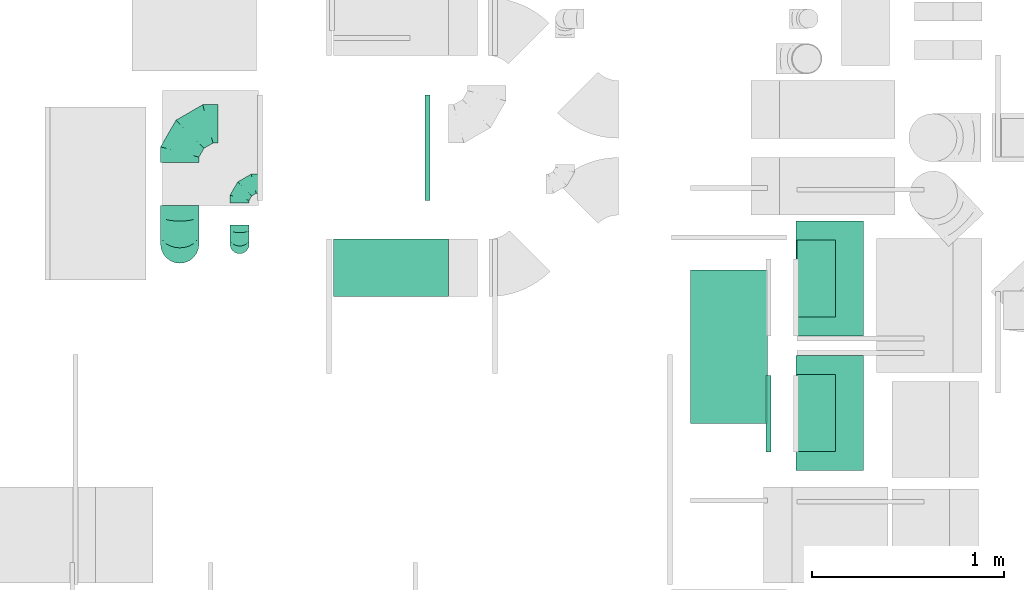
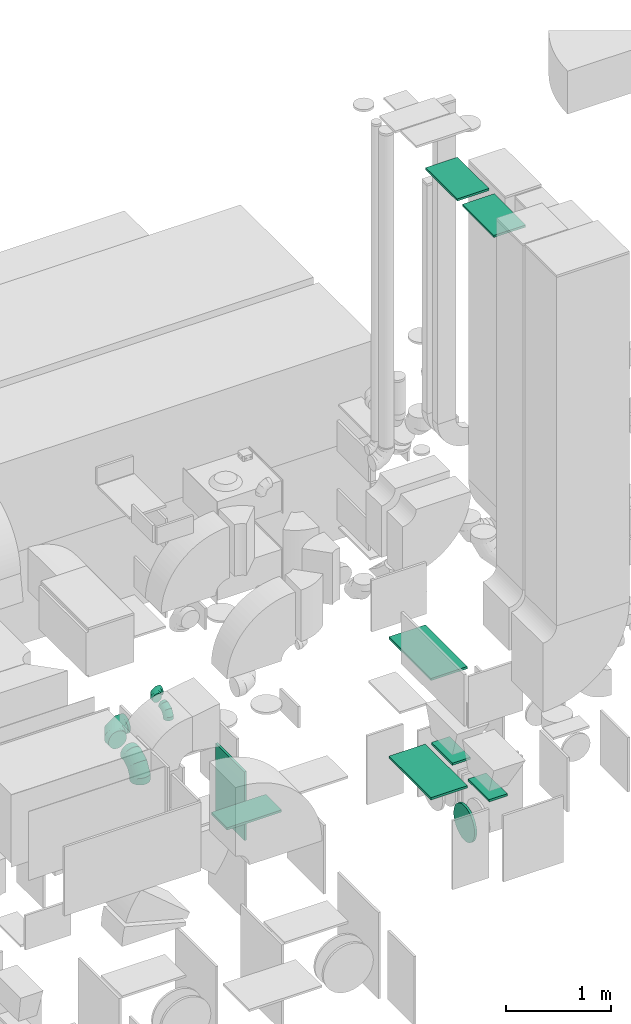
# One storey, part 15 of 59: 13 flow fittings.
"""IFC2X3 building model written with IfcOpenShell, lengths in millimetres."""

from ifc_helpers import new_model, entity, si_unit, converted_unit, derived_unit, direction, frame, origin, origin_2d_with_axis, place, context, subcontext, project, spatial, rectangle, extrude, faceted_brep, source, transform, mapped, material, type_object, type_shapes, element, save


model = new_model("IFC2X3")

# Units and contexts
model_context = context("Model", 3, precision=0.01, world=origin(), true_north=direction((6.12303176911189e-17, 1.0)))
body_context = subcontext(model_context, "Body", "Model", "MODEL_VIEW")
ifc_project = project(units=[si_unit("LENGTHUNIT", "METRE", prefix="MILLI"), si_unit("AREAUNIT", "SQUARE_METRE"), si_unit("VOLUMEUNIT", "CUBIC_METRE"), converted_unit("PLANEANGLEUNIT", "DEGREE", entity("IfcRatioMeasure", 0.0174532925199433), si_unit("PLANEANGLEUNIT", "RADIAN"), dimensions=[0, 0, 0, 0, 0, 0, 0]), si_unit("MASSUNIT", "GRAM", prefix="KILO"), derived_unit("MASSDENSITYUNIT", [(si_unit("MASSUNIT", "GRAM", prefix="KILO"), 1), (si_unit("LENGTHUNIT", "METRE"), -3)]), derived_unit("MOMENTOFINERTIAUNIT", [(si_unit("LENGTHUNIT", "METRE"), 4)]), si_unit("TIMEUNIT", "SECOND"), si_unit("FREQUENCYUNIT", "HERTZ"), si_unit("THERMODYNAMICTEMPERATUREUNIT", "DEGREE_CELSIUS"), derived_unit("THERMALTRANSMITTANCEUNIT", [(si_unit("MASSUNIT", "GRAM", prefix="KILO"), 1), (si_unit("THERMODYNAMICTEMPERATUREUNIT", "KELVIN"), -1), (si_unit("TIMEUNIT", "SECOND"), -3)]), derived_unit("VOLUMETRICFLOWRATEUNIT", [(si_unit("LENGTHUNIT", "METRE"), 3), (si_unit("TIMEUNIT", "SECOND"), -1)]), derived_unit("MASSFLOWRATEUNIT", [(si_unit("MASSUNIT", "GRAM", prefix="KILO"), 1), (si_unit("TIMEUNIT", "SECOND"), -1)]), derived_unit("ROTATIONALFREQUENCYUNIT", [(si_unit("TIMEUNIT", "SECOND"), -1)]), si_unit("ELECTRICCURRENTUNIT", "AMPERE"), si_unit("ELECTRICVOLTAGEUNIT", "VOLT"), si_unit("POWERUNIT", "WATT"), si_unit("FORCEUNIT", "NEWTON", prefix="KILO"), si_unit("ILLUMINANCEUNIT", "LUX"), si_unit("LUMINOUSFLUXUNIT", "LUMEN"), si_unit("LUMINOUSINTENSITYUNIT", "CANDELA"), derived_unit("USERDEFINED", [(si_unit("MASSUNIT", "GRAM", prefix="KILO"), -1), (si_unit("LENGTHUNIT", "METRE"), -2), (si_unit("TIMEUNIT", "SECOND"), 3), (si_unit("LUMINOUSFLUXUNIT", "LUMEN"), 1)]), derived_unit("LINEARVELOCITYUNIT", [(si_unit("LENGTHUNIT", "METRE"), 1), (si_unit("TIMEUNIT", "SECOND"), -1)]), si_unit("PRESSUREUNIT", "PASCAL"), derived_unit("USERDEFINED", [(si_unit("LENGTHUNIT", "METRE"), -2), (si_unit("MASSUNIT", "GRAM", prefix="KILO"), 1), (si_unit("TIMEUNIT", "SECOND"), -2)]), derived_unit("LINEARFORCEUNIT", [(si_unit("MASSUNIT", "GRAM", prefix="KILO"), 1), (si_unit("LENGTHUNIT", "METRE"), 1), (si_unit("TIMEUNIT", "SECOND"), -2), (si_unit("LENGTHUNIT", "METRE"), -1)]), derived_unit("PLANARFORCEUNIT", [(si_unit("MASSUNIT", "GRAM", prefix="KILO"), 1), (si_unit("LENGTHUNIT", "METRE"), 1), (si_unit("TIMEUNIT", "SECOND"), -2), (si_unit("LENGTHUNIT", "METRE"), -2)])], contexts=[model_context])

# Site, building, storey
site_placement = place(None, origin())
site = spatial("IfcSite", under=ifc_project, at=site_placement, CompositionType="ELEMENT")
building_placement = place(site_placement, origin())
building = spatial("IfcBuilding", under=site, at=building_placement, CompositionType="ELEMENT")
storey_placement = place(building_placement, frame((0.0, 0.0, 28200.0)))
storey = spatial("IfcBuildingStorey", under=building, at=storey_placement, CompositionType="ELEMENT", Elevation=28200.0)

# Flow fittings
ifc_material = material()
duct_fitting_type_1 = type_object("IfcDuctFittingType", PredefinedType="NOTDEFINED", material=ifc_material)
shared_shape_1 = source(origin(), body_context, "Body", "SweptSolid", [
    extrude(rectangle(XDim=26.0960000000006, YDim=400.0, at=origin_2d_with_axis()), frame((6.95, 0.0, -100.0)), (0.0, 0.0, 1.0), 200.0),
])
type_shapes(duct_fitting_type_1, [shared_shape_1])
flow_fitting_1_placement = place(storey_placement, frame((48410.88, 10109.01, 970.0), z_axis=(-1.0, 0.0, 0.0), x_axis=(0.0, 0.0, 1.0)))
element("IfcFlowFitting", 1, at=flow_fitting_1_placement, inside=storey, type_object=duct_fitting_type_1, material=ifc_material, context=body_context, shape_type="MappedRepresentation", body=[
    mapped(shared_shape_1, transform((0.0, 0.0, 0.0), scale=1.0)),
])
duct_fitting_type_2 = type_object("IfcDuctFittingType", PredefinedType="NOTDEFINED", material=ifc_material)
shared_shape_2 = source(origin(), body_context, "Body", "SweptSolid", [
    extrude(rectangle(XDim=24.9999999999999, YDim=600.0, at=origin_2d_with_axis()), frame((12.5, 0.0, -175.0)), (0.0, 0.0, 1.0), 350.0),
])
type_shapes(duct_fitting_type_2, [shared_shape_2])
for number, where, z_axis, x_axis in (
    (2, (48480.88, 10109.01, 7587.0), (1.0, 0.0, 0.0), (0.0, 0.0, 1.0)),
    (3, (48480.88, 10809.01, 7587.0), (1.0, 0.0, 0.0), (0.0, 0.0, 1.0)),
):
    element("IfcFlowFitting", number, at=place(storey_placement, frame(where, z_axis=z_axis, x_axis=x_axis)), inside=storey, type_object=duct_fitting_type_2, material=ifc_material, context=body_context, shape_type="MappedRepresentation", body=[
        mapped(shared_shape_2, transform((0.0, 0.0, 0.0), scale=1.0)),
    ])
duct_fitting_type_3 = type_object("IfcDuctFittingType", PredefinedType="NOTDEFINED", material=ifc_material)
shared_shape_3 = source(origin(), body_context, "Body", "SweptSolid", [
    extrude(rectangle(XDim=300.0, YDim=26.0960000000433, at=origin_2d_with_axis()), frame((6.95, 0.0, -300.0), z_axis=(0.0, 0.0, 1.0), x_axis=(0.0, -1.0, 0.0)), (0.0, 0.0, 1.0), 600.0),
])
type_shapes(duct_fitting_type_3, [shared_shape_3])
flow_fitting_2_placement = place(storey_placement, frame((46194.5, 10864.6, 1000.0), z_axis=(1.0, 0.0, 0.0), x_axis=(0.0, 0.0, 1.0)))
element("IfcFlowFitting", 4, at=flow_fitting_2_placement, inside=storey, type_object=duct_fitting_type_3, material=ifc_material, context=body_context, shape_type="MappedRepresentation", body=[
    mapped(shared_shape_3, transform((0.0, 0.0, 0.0), scale=1.0)),
])
duct_fitting_type_4 = type_object("IfcDuctFittingType", PredefinedType="NOTDEFINED", material=ifc_material)
shared_shape_4 = source(origin(), body_context, "Body", "SweptSolid", [
    extrude(rectangle(XDim=24.9999999999999, YDim=550.0, at=origin_2d_with_axis()), frame((12.5, 0.0, -400.0)), (0.0, 0.0, 1.0), 800.0),
])
type_shapes(duct_fitting_type_4, [shared_shape_4])
flow_fitting_3_placement = place(storey_placement, frame((46373.53, 11489.6, 800.0)))
element("IfcFlowFitting", 5, at=flow_fitting_3_placement, inside=storey, type_object=duct_fitting_type_4, material=ifc_material, context=body_context, shape_type="MappedRepresentation", body=[
    mapped(shared_shape_4, transform((0.0, 0.0, 0.0), scale=1.0)),
])
duct_fitting_type_5 = type_object("IfcDuctFittingType", PredefinedType="NOTDEFINED", material=ifc_material)
shared_shape_5 = source(origin(), body_context, "Body", "SweptSolid", [
    extrude(rectangle(XDim=400.0, YDim=26.096, at=origin_2d_with_axis()), frame((6.95, 0.0, -100.0), z_axis=(0.0, 0.0, 1.0), x_axis=(0.0, -1.0, 0.0)), (0.0, 0.0, 1.0), 200.0),
])
type_shapes(duct_fitting_type_5, [shared_shape_5])
flow_fitting_4_placement = place(storey_placement, frame((48410.88, 10809.01, 970.0), z_axis=(-1.0, 0.0, 0.0), x_axis=(0.0, 0.0, 1.0)))
element("IfcFlowFitting", 6, at=flow_fitting_4_placement, inside=storey, type_object=duct_fitting_type_5, material=ifc_material, context=body_context, shape_type="MappedRepresentation", body=[
    mapped(shared_shape_5, transform((0.0, 0.0, 0.0), scale=1.0)),
])
duct_fitting_type_6 = type_object("IfcDuctFittingType", PredefinedType="NOTDEFINED", material=ifc_material)
shared_shape_6 = source(origin(), body_context, "Body", "SweptSolid", [
    extrude(rectangle(XDim=400.0, YDim=26.0960000001169, at=origin_2d_with_axis()), frame((6.95, 0.0, -400.0), z_axis=(0.0, 0.0, 1.0), x_axis=(0.0, -1.0, 0.0)), (0.0, 0.0, 1.0), 800.0),
])
type_shapes(duct_fitting_type_6, [shared_shape_6])
for number, where, z_axis, x_axis in (
    (7, (47955.03, 10453.67, 1100.0), (0.0, -1.0, 0.0), (0.0, 0.0, 1.0)),
    (8, (47955.03, 10453.67, 2500.0), (0.0, -1.0, 0.0), (0.0, 0.0, -1.0)),
):
    element("IfcFlowFitting", number, at=place(storey_placement, frame(where, z_axis=z_axis, x_axis=x_axis)), inside=storey, type_object=duct_fitting_type_6, material=ifc_material, context=body_context, shape_type="MappedRepresentation", body=[
        mapped(shared_shape_6, transform((0.0, 0.0, 0.0), scale=1.0)),
    ])
duct_fitting_type_7 = type_object("IfcDuctFittingType", PredefinedType="NOTDEFINED", material=ifc_material)
shared_shape_7 = source(origin(), body_context, "Body", "Brep", [
    faceted_brep([(-100.0, 0.0, -50.0), (-100.0, -12.94, -48.3), (-100.0, -25.0, -43.3), (-100.0, -35.36, -35.36), (-100.0, -43.3, -25.0), (-100.0, -48.3, -12.94), (-100.0, -50.0, 0.0), (-100.0, -48.3, 12.94), (-100.0, -43.3, 25.0), (-100.0, -35.36, 35.36), (-100.0, -25.0, 43.3), (-100.0, -12.94, 48.3), (-100.0, 0.0, 50.0), (-100.0, 12.94, 48.3), (-100.0, 25.0, 43.3), (-100.0, 35.36, 35.36), (-100.0, 43.3, 25.0), (-100.0, 48.3, 12.94), (-100.0, 50.0, 0.0), (-100.0, 48.3, -12.94), (-100.0, 43.3, -25.0), (-100.0, 35.36, -35.36), (-100.0, 25.0, -43.3), (-100.0, 12.94, -48.3), (-76.67, 12.94, 48.3), (-79.9, 25.0, 43.3), (-73.21, 0.0, 50.0), (-82.68, 35.36, 35.36), (-86.15, 48.3, 12.94), (-86.6, 50.0, 0.0), (-84.81, 43.3, 25.0), (-84.81, 43.3, -25.0), (-82.68, 35.36, -35.36), (-86.15, 48.3, -12.94), (-76.67, 12.94, -48.3), (-73.21, 0.0, -50.0), (-79.9, 25.0, -43.3), (-69.74, -12.94, -48.3), (-66.51, -25.0, -43.3), (-63.73, -35.36, -35.36), (-61.6, -43.3, -25.0), (-60.26, -48.3, -12.94), (-59.81, -50.0, 0.0), (-60.26, -48.3, 12.94), (-61.6, -43.3, 25.0), (-63.73, -35.36, 35.36), (-66.51, -25.0, 43.3), (-69.74, -12.94, 48.3), (-36.27, 36.27, 48.3), (-45.1, 45.1, 43.3), (-26.79, 26.79, 50.0), (-52.68, 52.68, 35.36), (-58.49, 58.49, 25.0), (-62.15, 62.15, 12.94), (-63.4, 63.4, 0.0), (-62.15, 62.15, -12.94), (-58.49, 58.49, -25.0), (-52.68, 52.68, -35.36), (-36.27, 36.27, -48.3), (-26.79, 26.79, -50.0), (-45.1, 45.1, -43.3), (-17.32, 17.32, -48.3), (-8.49, 8.49, -43.3), (-0.91, 0.91, -35.36), (4.9, -4.9, -25.0), (8.56, -8.56, -12.94), (9.81, -9.81, 0.0), (8.56, -8.56, 12.94), (4.9, -4.9, 25.0), (-0.91, 0.91, 35.36), (-8.49, 8.49, 43.3), (-17.32, 17.32, 48.3), (-12.94, 76.67, 48.3), (-25.0, 79.9, 43.3), (0.0, 73.21, 50.0), (-35.36, 82.68, 35.36), (-43.3, 84.81, 25.0), (-48.3, 86.15, 12.94), (-50.0, 86.6, 0.0), (-48.3, 86.15, -12.94), (-43.3, 84.81, -25.0), (-35.36, 82.68, -35.36), (-12.94, 76.67, -48.3), (0.0, 73.21, -50.0), (-25.0, 79.9, -43.3), (12.94, 69.74, -48.3), (25.0, 66.51, -43.3), (35.36, 63.73, -35.36), (43.3, 61.6, -25.0), (48.3, 60.26, -12.94), (50.0, 59.81, 0.0), (48.3, 60.26, 12.94), (43.3, 61.6, 25.0), (35.36, 63.73, 35.36), (25.0, 66.51, 43.3), (12.94, 69.74, 48.3), (-12.94, 100.0, -48.3), (-25.0, 100.0, -43.3), (-35.36, 100.0, -35.36), (-43.3, 100.0, -25.0), (-48.3, 100.0, -12.94), (-50.0, 100.0, 0.0), (-48.3, 100.0, 12.94), (-43.3, 100.0, 25.0), (-35.36, 100.0, 35.36), (-25.0, 100.0, 43.3), (-12.94, 100.0, 48.3), (0.0, 100.0, 50.0), (12.94, 100.0, 48.3), (25.0, 100.0, 43.3), (35.36, 100.0, 35.36), (43.3, 100.0, 25.0), (48.3, 100.0, 12.94), (50.0, 100.0, 0.0), (48.3, 100.0, -12.94), (43.3, 100.0, -25.0), (35.36, 100.0, -35.36), (25.0, 100.0, -43.3), (12.94, 100.0, -48.3), (0.0, 100.0, -50.0)], [[[0, 1, 2, 3, 4, 5, 6, 7, 8, 9, 10, 11, 12, 13, 14, 15, 16, 17, 18, 19, 20, 21, 22, 23]], [[24, 25, 14, 13]], [[26, 24, 13, 12]], [[14, 25, 27, 15]], [[28, 29, 18, 17]], [[30, 28, 17, 16]], [[15, 27, 30, 16]], [[20, 31, 32, 21]], [[33, 31, 20, 19]], [[18, 29, 33, 19]], [[34, 35, 0, 23]], [[36, 34, 23, 22]], [[32, 36, 22, 21]], [[2, 1, 37, 38]], [[3, 2, 38, 39]], [[0, 35, 37, 1]], [[5, 4, 40, 41]], [[6, 5, 41, 42]], [[3, 39, 40, 4]], [[6, 42, 43, 7]], [[7, 43, 44, 8]], [[8, 44, 45, 9]], [[10, 46, 47, 11]], [[11, 47, 26, 12]], [[10, 9, 45, 46]], [[48, 49, 25, 24]], [[50, 48, 24, 26]], [[27, 25, 49, 51]], [[52, 53, 28, 30]], [[51, 52, 30, 27]], [[29, 28, 53, 54]], [[55, 56, 31, 33]], [[54, 55, 33, 29]], [[57, 32, 31, 56]], [[58, 59, 35, 34]], [[60, 58, 34, 36]], [[57, 60, 36, 32]], [[37, 35, 59, 61]], [[38, 37, 61, 62]], [[39, 38, 62, 63]], [[41, 40, 64, 65]], [[42, 41, 65, 66]], [[63, 64, 40, 39]], [[43, 42, 66, 67]], [[44, 43, 67, 68]], [[68, 69, 45, 44]], [[46, 45, 69, 70]], [[47, 46, 70, 71]], [[26, 47, 71, 50]], [[72, 73, 49, 48]], [[74, 72, 48, 50]], [[51, 49, 73, 75]], [[76, 77, 53, 52]], [[75, 76, 52, 51]], [[54, 53, 77, 78]], [[79, 80, 56, 55]], [[78, 79, 55, 54]], [[81, 57, 56, 80]], [[82, 83, 59, 58]], [[84, 82, 58, 60]], [[81, 84, 60, 57]], [[61, 59, 83, 85]], [[62, 61, 85, 86]], [[63, 62, 86, 87]], [[65, 64, 88, 89]], [[66, 65, 89, 90]], [[87, 88, 64, 63]], [[67, 66, 90, 91]], [[68, 67, 91, 92]], [[92, 93, 69, 68]], [[70, 69, 93, 94]], [[71, 70, 94, 95]], [[50, 71, 95, 74]], [[96, 97, 98, 99, 100, 101, 102, 103, 104, 105, 106, 107, 108, 109, 110, 111, 112, 113, 114, 115, 116, 117, 118, 119]], [[72, 74, 107, 106]], [[73, 72, 106, 105]], [[75, 73, 105, 104]], [[77, 76, 103, 102]], [[78, 77, 102, 101]], [[75, 104, 103, 76]], [[78, 101, 100, 79]], [[79, 100, 99, 80]], [[80, 99, 98, 81]], [[96, 119, 83, 82]], [[97, 96, 82, 84]], [[84, 81, 98, 97]], [[83, 119, 118, 85]], [[85, 118, 117, 86]], [[86, 117, 116, 87]], [[88, 115, 114, 89]], [[89, 114, 113, 90]], [[87, 116, 115, 88]], [[91, 90, 113, 112]], [[92, 91, 112, 111]], [[93, 92, 111, 110]], [[95, 94, 109, 108]], [[74, 95, 108, 107]], [[110, 109, 94, 93]]]),
])
type_shapes(duct_fitting_type_7, [shared_shape_7])
for number, where, z_axis, x_axis in (
    (9, (45406.65, 11302.74, 2403.42), (0.0, 0.0, 1.0), (-1.0, 0.0, 0.0)),
    (10, (45406.65, 10988.57, 2403.42), (1.0, 0.0, 0.0), (0.0, -1.0, 0.0)),
):
    element("IfcFlowFitting", number, at=place(storey_placement, frame(where, z_axis=z_axis, x_axis=x_axis)), inside=storey, type_object=duct_fitting_type_7, material=ifc_material, context=body_context, shape_type="MappedRepresentation", body=[
        mapped(shared_shape_7, transform((0.0, 0.0, 0.0), scale=1.0)),
    ])
duct_fitting_type_8 = type_object("IfcDuctFittingType", PredefinedType="NOTDEFINED", material=ifc_material)
shared_shape_8 = source(origin(), body_context, "Body", "Brep", [
    faceted_brep([(-200.0, 0.0, -100.0), (-200.0, -25.88, -96.59), (-200.0, -50.0, -86.6), (-200.0, -70.71, -70.71), (-200.0, -86.6, -50.0), (-200.0, -96.59, -25.88), (-200.0, -100.0, 0.0), (-200.0, -96.59, 25.88), (-200.0, -86.6, 50.0), (-200.0, -70.71, 70.71), (-200.0, -50.0, 86.6), (-200.0, -25.88, 96.59), (-200.0, 0.0, 100.0), (-200.0, 25.88, 96.59), (-200.0, 50.0, 86.6), (-200.0, 70.71, 70.71), (-200.0, 86.6, 50.0), (-200.0, 96.59, 25.88), (-200.0, 100.0, 0.0), (-200.0, 96.59, -25.88), (-200.0, 86.6, -50.0), (-200.0, 70.71, -70.71), (-200.0, 50.0, -86.6), (-200.0, 25.88, -96.59), (-153.35, 25.88, 96.59), (-159.81, 50.0, 86.6), (-146.41, 0.0, 100.0), (-165.36, 70.71, 70.71), (-172.29, 96.59, 25.88), (-173.21, 100.0, 0.0), (-169.62, 86.6, 50.0), (-169.62, 86.6, -50.0), (-165.36, 70.71, -70.71), (-172.29, 96.59, -25.88), (-153.35, 25.88, -96.59), (-146.41, 0.0, -100.0), (-159.81, 50.0, -86.6), (-139.48, -25.88, -96.59), (-133.01, -50.0, -86.6), (-127.46, -70.71, -70.71), (-123.21, -86.6, -50.0), (-120.53, -96.59, -25.88), (-119.62, -100.0, 0.0), (-120.53, -96.59, 25.88), (-123.21, -86.6, 50.0), (-127.46, -70.71, 70.71), (-133.01, -50.0, 86.6), (-139.48, -25.88, 96.59), (-72.54, 72.54, 96.59), (-90.19, 90.19, 86.6), (-53.59, 53.59, 100.0), (-105.35, 105.35, 70.71), (-116.99, 116.99, 50.0), (-124.3, 124.3, 25.88), (-126.79, 126.79, 0.0), (-124.3, 124.3, -25.88), (-116.99, 116.99, -50.0), (-105.35, 105.35, -70.71), (-72.54, 72.54, -96.59), (-53.59, 53.59, -100.0), (-90.19, 90.19, -86.6), (-34.64, 34.64, -96.59), (-16.99, 16.99, -86.6), (-1.83, 1.83, -70.71), (9.81, -9.81, -50.0), (17.12, -17.12, -25.88), (19.62, -19.62, 0.0), (17.12, -17.12, 25.88), (9.81, -9.81, 50.0), (-1.83, 1.83, 70.71), (-16.99, 16.99, 86.6), (-34.64, 34.64, 96.59), (-25.88, 153.35, 96.59), (-50.0, 159.81, 86.6), (0.0, 146.41, 100.0), (-70.71, 165.36, 70.71), (-86.6, 169.62, 50.0), (-96.59, 172.29, 25.88), (-100.0, 173.21, 0.0), (-96.59, 172.29, -25.88), (-86.6, 169.62, -50.0), (-70.71, 165.36, -70.71), (-25.88, 153.35, -96.59), (0.0, 146.41, -100.0), (-50.0, 159.81, -86.6), (25.88, 139.48, -96.59), (50.0, 133.01, -86.6), (70.71, 127.46, -70.71), (86.6, 123.21, -50.0), (96.59, 120.53, -25.88), (100.0, 119.62, 0.0), (96.59, 120.53, 25.88), (86.6, 123.21, 50.0), (70.71, 127.46, 70.71), (50.0, 133.01, 86.6), (25.88, 139.48, 96.59), (-25.88, 200.0, -96.59), (-50.0, 200.0, -86.6), (-70.71, 200.0, -70.71), (-86.6, 200.0, -50.0), (-96.59, 200.0, -25.88), (-100.0, 200.0, 0.0), (-96.59, 200.0, 25.88), (-86.6, 200.0, 50.0), (-70.71, 200.0, 70.71), (-50.0, 200.0, 86.6), (-25.88, 200.0, 96.59), (0.0, 200.0, 100.0), (25.88, 200.0, 96.59), (50.0, 200.0, 86.6), (70.71, 200.0, 70.71), (86.6, 200.0, 50.0), (96.59, 200.0, 25.88), (100.0, 200.0, 0.0), (96.59, 200.0, -25.88), (86.6, 200.0, -50.0), (70.71, 200.0, -70.71), (50.0, 200.0, -86.6), (25.88, 200.0, -96.59), (0.0, 200.0, -100.0)], [[[0, 1, 2, 3, 4, 5, 6, 7, 8, 9, 10, 11, 12, 13, 14, 15, 16, 17, 18, 19, 20, 21, 22, 23]], [[24, 25, 14, 13]], [[26, 24, 13, 12]], [[14, 25, 27, 15]], [[28, 29, 18, 17]], [[30, 28, 17, 16]], [[15, 27, 30, 16]], [[20, 31, 32, 21]], [[33, 31, 20, 19]], [[18, 29, 33, 19]], [[34, 35, 0, 23]], [[36, 34, 23, 22]], [[32, 36, 22, 21]], [[1, 0, 35, 37]], [[2, 1, 37, 38]], [[38, 39, 3, 2]], [[5, 4, 40, 41]], [[6, 5, 41, 42]], [[39, 40, 4, 3]], [[6, 42, 43, 7]], [[7, 43, 44, 8]], [[8, 44, 45, 9]], [[9, 45, 46, 10]], [[10, 46, 47, 11]], [[26, 12, 11, 47]], [[48, 49, 25, 24]], [[50, 48, 24, 26]], [[27, 25, 49, 51]], [[52, 53, 28, 30]], [[51, 52, 30, 27]], [[29, 28, 53, 54]], [[55, 56, 31, 33]], [[54, 55, 33, 29]], [[32, 31, 56, 57]], [[58, 59, 35, 34]], [[60, 58, 34, 36]], [[57, 60, 36, 32]], [[37, 35, 59, 61]], [[38, 37, 61, 62]], [[39, 38, 62, 63]], [[41, 40, 64, 65]], [[42, 41, 65, 66]], [[63, 64, 40, 39]], [[43, 42, 66, 67]], [[44, 43, 67, 68]], [[68, 69, 45, 44]], [[46, 45, 69, 70]], [[47, 46, 70, 71]], [[26, 47, 71, 50]], [[72, 73, 49, 48]], [[74, 72, 48, 50]], [[51, 49, 73, 75]], [[76, 77, 53, 52]], [[75, 76, 52, 51]], [[54, 53, 77, 78]], [[79, 80, 56, 55]], [[78, 79, 55, 54]], [[57, 56, 80, 81]], [[82, 83, 59, 58]], [[84, 82, 58, 60]], [[81, 84, 60, 57]], [[61, 59, 83, 85]], [[62, 61, 85, 86]], [[63, 62, 86, 87]], [[65, 64, 88, 89]], [[66, 65, 89, 90]], [[87, 88, 64, 63]], [[67, 66, 90, 91]], [[68, 67, 91, 92]], [[92, 93, 69, 68]], [[70, 69, 93, 94]], [[71, 70, 94, 95]], [[50, 71, 95, 74]], [[96, 97, 98, 99, 100, 101, 102, 103, 104, 105, 106, 107, 108, 109, 110, 111, 112, 113, 114, 115, 116, 117, 118, 119]], [[72, 74, 107, 106]], [[73, 72, 106, 105]], [[75, 73, 105, 104]], [[102, 101, 78, 77]], [[103, 102, 77, 76]], [[75, 104, 103, 76]], [[78, 101, 100, 79]], [[79, 100, 99, 80]], [[80, 99, 98, 81]], [[84, 97, 96, 82]], [[82, 96, 119, 83]], [[84, 81, 98, 97]], [[118, 117, 86, 85]], [[119, 118, 85, 83]], [[116, 87, 86, 117]], [[88, 115, 114, 89]], [[89, 114, 113, 90]], [[115, 88, 87, 116]], [[91, 90, 113, 112]], [[92, 91, 112, 111]], [[111, 110, 93, 92]], [[95, 94, 109, 108]], [[74, 95, 108, 107]], [[110, 109, 94, 93]]]),
])
type_shapes(duct_fitting_type_8, [shared_shape_8])
for number, where, z_axis, x_axis in (
    (11, (45095.05, 11614.6, 1900.0), (0.0, 0.0, 1.0), (-1.0, 0.0, 0.0)),
    (12, (45095.05, 10988.58, 1900.0), (1.0, 0.0, 0.0), (0.0, -1.0, 0.0)),
):
    element("IfcFlowFitting", number, at=place(storey_placement, frame(where, z_axis=z_axis, x_axis=x_axis)), inside=storey, type_object=duct_fitting_type_8, material=ifc_material, context=body_context, shape_type="MappedRepresentation", body=[
        mapped(shared_shape_8, transform((0.0, 0.0, 0.0), scale=1.0)),
    ])
duct_fitting_type_9 = type_object("IfcDuctFittingType", PredefinedType="NOTDEFINED", material=ifc_material)
shared_shape_9 = source(origin(), body_context, "Body", "Brep", [
    faceted_brep([(20.0, 0.0, -200.0), (20.0, 44.5, -194.99), (20.0, 86.78, -180.19), (20.0, 124.7, -156.37), (20.0, 156.37, -124.7), (20.0, 180.19, -86.78), (20.0, 194.99, -44.5), (20.0, 200.0, 0.0), (20.0, 194.99, 44.5), (20.0, 180.19, 86.78), (20.0, 156.37, 124.7), (20.0, 124.7, 156.37), (20.0, 86.78, 180.19), (20.0, 44.5, 194.99), (20.0, 0.0, 200.0), (20.0, -44.5, 194.99), (20.0, -86.78, 180.19), (20.0, -124.7, 156.37), (20.0, -156.37, 124.7), (20.0, -180.19, 86.78), (20.0, -194.99, 44.5), (20.0, -200.0, 0.0), (20.0, -194.99, -44.5), (20.0, -180.19, -86.78), (20.0, -156.37, -124.7), (20.0, -124.7, -156.37), (20.0, -86.78, -180.19), (20.0, -44.5, -194.99), (0.0, 0.0, 200.0), (0.0, -30.6, 196.55), (0.0, -44.5, 194.99), (-6.1, -22.25, 197.49), (-6.1, 0.0, 200.0), (-6.1, -44.5, 194.99), (0.0, -65.64, 187.59), (-6.1, -65.64, 187.59), (0.0, -86.78, 180.19), (-6.1, -86.78, 180.19), (0.0, -105.74, 168.28), (-6.1, -105.74, 168.28), (0.0, -124.7, 156.37), (-6.1, -124.7, 156.37), (0.0, -140.53, 140.53), (-6.1, -140.53, 140.53), (0.0, -156.37, 124.7), (-6.1, -156.37, 124.7), (0.0, -168.28, 105.74), (0.0, -180.19, 86.78), (-6.1, -168.28, 105.74), (-6.1, -180.19, 86.78), (0.0, -187.59, 65.64), (-6.1, -187.59, 65.64), (0.0, -194.99, 44.5), (-6.1, -194.99, 44.5), (0.0, -197.49, 22.25), (-6.1, -196.55, 30.6), (-6.1, -200.0, 0.0), (0.0, -200.0, 0.0), (0.0, -196.55, -30.6), (0.0, -194.99, -44.5), (-6.1, -197.49, -22.25), (-6.1, -194.99, -44.5), (0.0, -187.59, -65.64), (-6.1, -187.59, -65.64), (0.0, -180.19, -86.78), (-6.1, -180.19, -86.78), (0.0, -168.28, -105.74), (-6.1, -168.28, -105.74), (0.0, -156.37, -124.7), (-6.1, -156.37, -124.7), (0.0, -140.53, -140.53), (-6.1, -140.53, -140.53), (0.0, -124.7, -156.37), (-6.1, -124.7, -156.37), (0.0, -105.74, -168.28), (-6.1, -105.74, -168.28), (-6.1, -86.78, -180.19), (0.0, -86.78, -180.19), (0.0, -44.5, -194.99), (0.0, -65.64, -187.59), (-6.1, -44.5, -194.99), (-6.1, -65.64, -187.59), (0.0, 0.0, -200.0), (0.0, -30.6, -196.55), (-6.1, -22.25, -197.49), (-6.1, 0.0, -200.0), (0.0, 30.6, -196.55), (0.0, 44.5, -194.99), (-6.1, 22.25, -197.49), (-6.1, 44.5, -194.99), (0.0, 65.64, -187.59), (-6.1, 65.64, -187.59), (0.0, 86.78, -180.19), (-6.1, 86.78, -180.19), (0.0, 105.74, -168.28), (-6.1, 105.74, -168.28), (0.0, 124.7, -156.37), (-6.1, 124.7, -156.37), (0.0, 140.53, -140.53), (-6.1, 140.53, -140.53), (0.0, 156.37, -124.7), (-6.1, 156.37, -124.7), (0.0, 168.28, -105.74), (-6.1, 168.28, -105.74), (0.0, 180.19, -86.78), (-6.1, 180.19, -86.78), (0.0, 194.99, -44.5), (0.0, 196.55, -30.6), (-6.1, 194.99, -44.5), (-6.1, 197.49, -22.25), (0.0, 200.0, 0.0), (-6.1, 200.0, 0.0), (0.0, 187.59, -65.64), (-6.1, 187.59, -65.64), (0.0, 196.55, 30.6), (0.0, 194.99, 44.5), (-6.1, 197.49, 22.25), (-6.1, 194.99, 44.5), (0.0, 187.59, 65.64), (-6.1, 187.59, 65.64), (0.0, 180.19, 86.78), (-6.1, 180.19, 86.78), (0.0, 168.28, 105.74), (-6.1, 168.28, 105.74), (0.0, 156.37, 124.7), (-6.1, 156.37, 124.7), (0.0, 140.53, 140.53), (-6.1, 140.53, 140.53), (0.0, 124.7, 156.37), (-6.1, 124.7, 156.37), (0.0, 105.74, 168.28), (0.0, 86.78, 180.19), (-6.1, 105.74, 168.28), (-6.1, 86.78, 180.19), (0.0, 65.64, 187.59), (-6.1, 65.64, 187.59), (0.0, 44.5, 194.99), (-6.1, 44.5, 194.99), (0.0, 22.25, 197.49), (-6.1, 30.6, 196.55)], [[[0, 1, 2, 3, 4, 5, 6, 7, 8, 9, 10, 11, 12, 13, 14, 15, 16, 17, 18, 19, 20, 21, 22, 23, 24, 25, 26, 27]], [[15, 14, 28]], [[15, 28, 29]], [[15, 29, 30]], [[31, 29, 28]], [[31, 28, 32]], [[31, 33, 29]], [[29, 33, 30]], [[30, 16, 15]], [[16, 30, 34]], [[30, 33, 34]], [[35, 34, 33]], [[36, 34, 35]], [[35, 37, 36]], [[16, 34, 36]], [[16, 36, 17]], [[17, 36, 38]], [[36, 37, 38]], [[39, 38, 37]], [[39, 40, 38]], [[39, 41, 40]], [[17, 38, 40]], [[40, 18, 17]], [[18, 40, 42]], [[41, 42, 40]], [[43, 42, 41]], [[44, 42, 43]], [[43, 45, 44]], [[18, 42, 44]], [[19, 18, 44]], [[19, 44, 46]], [[19, 46, 47]], [[46, 44, 45]], [[48, 46, 45]], [[46, 48, 47]], [[48, 49, 47]], [[47, 20, 19]], [[20, 47, 50]], [[47, 49, 50]], [[51, 50, 49]], [[52, 50, 51]], [[51, 53, 52]], [[20, 50, 52]], [[20, 52, 21]], [[21, 52, 54]], [[54, 52, 55]], [[53, 55, 52]], [[54, 55, 56]], [[54, 56, 57]], [[21, 54, 57]], [[22, 21, 57]], [[22, 57, 58]], [[22, 58, 59]], [[60, 58, 57]], [[60, 57, 56]], [[60, 61, 58]], [[58, 61, 59]], [[59, 23, 22]], [[23, 59, 62]], [[59, 61, 62]], [[63, 62, 61]], [[64, 62, 63]], [[63, 65, 64]], [[23, 62, 64]], [[23, 64, 24]], [[24, 64, 66]], [[64, 65, 66]], [[67, 66, 65]], [[67, 68, 66]], [[67, 69, 68]], [[24, 66, 68]], [[68, 25, 24]], [[25, 68, 70]], [[69, 70, 68]], [[71, 70, 69]], [[72, 70, 71]], [[71, 73, 72]], [[25, 70, 72]], [[72, 26, 25]], [[26, 72, 74]], [[74, 72, 73]], [[75, 74, 73]], [[74, 75, 76]], [[76, 77, 74]], [[26, 74, 77]], [[78, 27, 26]], [[26, 79, 78]], [[80, 78, 79]], [[26, 77, 79]], [[79, 77, 81]], [[76, 81, 77]], [[81, 80, 79]], [[0, 27, 82]], [[27, 83, 82]], [[27, 78, 83]], [[78, 80, 83]], [[84, 83, 80]], [[83, 84, 82]], [[84, 85, 82]], [[1, 0, 82]], [[1, 82, 86]], [[1, 86, 87]], [[88, 86, 82]], [[88, 82, 85]], [[88, 89, 86]], [[86, 89, 87]], [[87, 2, 1]], [[2, 87, 90]], [[87, 89, 90]], [[91, 90, 89]], [[92, 90, 91]], [[91, 93, 92]], [[2, 90, 92]], [[2, 92, 3]], [[3, 92, 94]], [[92, 93, 94]], [[95, 94, 93]], [[95, 96, 94]], [[95, 97, 96]], [[3, 94, 96]], [[96, 4, 3]], [[4, 96, 98]], [[97, 98, 96]], [[99, 98, 97]], [[100, 98, 99]], [[99, 101, 100]], [[4, 98, 100]], [[100, 5, 4]], [[5, 100, 102]], [[102, 100, 101]], [[103, 102, 101]], [[102, 103, 104]], [[103, 105, 104]], [[5, 102, 104]], [[106, 7, 6]], [[7, 106, 107]], [[106, 108, 107]], [[109, 107, 108]], [[107, 109, 110]], [[109, 111, 110]], [[7, 107, 110]], [[106, 6, 5]], [[5, 112, 106]], [[108, 106, 112]], [[5, 104, 112]], [[112, 104, 113]], [[105, 113, 104]], [[113, 108, 112]], [[8, 7, 110]], [[8, 110, 114]], [[8, 114, 115]], [[116, 114, 110]], [[116, 110, 111]], [[116, 117, 114]], [[114, 117, 115]], [[115, 9, 8]], [[9, 115, 118]], [[115, 117, 118]], [[119, 118, 117]], [[120, 118, 119]], [[119, 121, 120]], [[9, 118, 120]], [[9, 120, 10]], [[10, 120, 122]], [[120, 121, 122]], [[123, 122, 121]], [[123, 124, 122]], [[123, 125, 124]], [[10, 122, 124]], [[124, 11, 10]], [[11, 124, 126]], [[125, 126, 124]], [[127, 126, 125]], [[128, 126, 127]], [[127, 129, 128]], [[11, 126, 128]], [[12, 11, 128]], [[12, 128, 130]], [[12, 130, 131]], [[130, 128, 129]], [[132, 130, 129]], [[130, 132, 131]], [[132, 133, 131]], [[131, 13, 12]], [[13, 131, 134]], [[131, 133, 134]], [[135, 134, 133]], [[136, 134, 135]], [[135, 137, 136]], [[13, 134, 136]], [[13, 136, 14]], [[14, 136, 138]], [[138, 136, 139]], [[137, 139, 136]], [[138, 139, 32]], [[138, 32, 28]], [[14, 138, 28]], [[56, 55, 53, 51, 49, 48, 45, 43, 41, 39, 37, 35, 33, 31, 32, 139, 137, 135, 133, 132, 129, 127, 125, 123, 121, 119, 117, 116, 111, 109, 108, 113, 105, 103, 101, 99, 97, 95, 93, 91, 89, 88, 85, 84, 80, 81, 76, 75, 73, 71, 69, 67, 65, 63, 61, 60]]]),
])
type_shapes(duct_fitting_type_9, [shared_shape_9])
flow_fitting_5_placement = place(storey_placement, frame((48155.03, 10105.16, 659.61), z_axis=(0.0, 0.0, -1.0), x_axis=(1.0, 0.0, 0.0)))
element("IfcFlowFitting", 13, at=flow_fitting_5_placement, inside=storey, type_object=duct_fitting_type_9, material=ifc_material, context=body_context, shape_type="MappedRepresentation", body=[
    mapped(shared_shape_9, transform((0.0, 0.0, 0.0), scale=1.0)),
])

save(model, "model.ifc")
